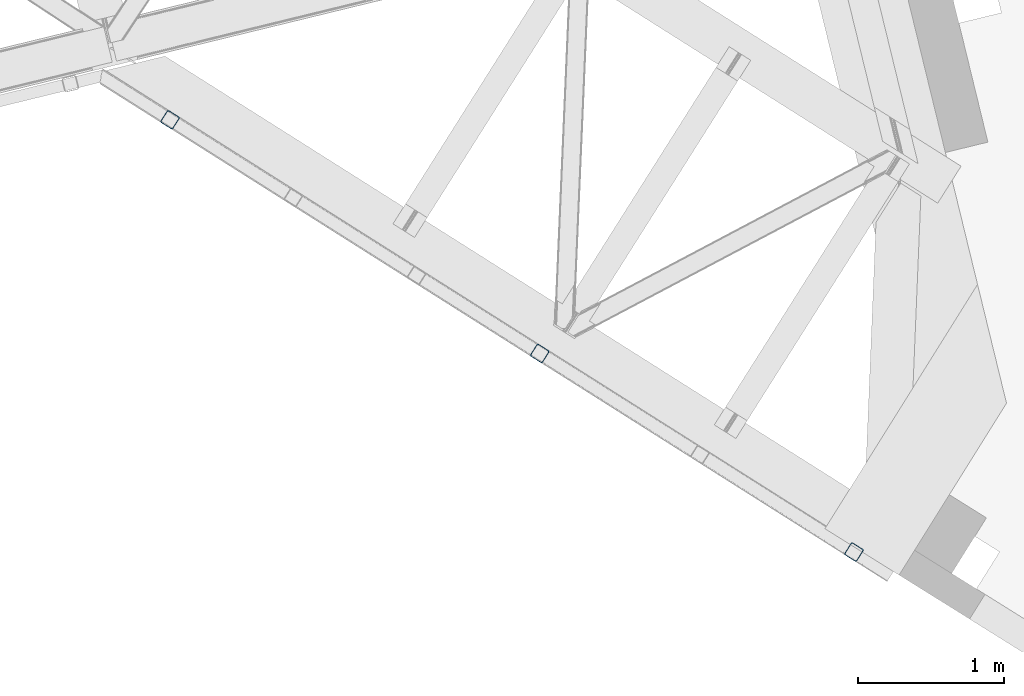
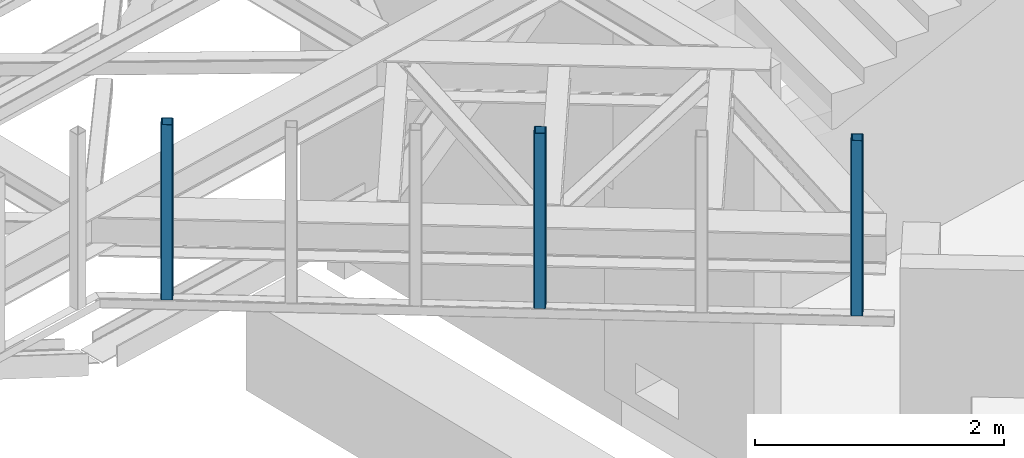
# One storey, part 9 of 67: 3 columns.
"""IFC4 building model written with IfcOpenShell, lengths in millimetres."""

from ifc_helpers import new_model, entity, si_unit, converted_unit, derived_unit, direction, frame, origin, place, context, subcontext, project, spatial, indexed_curve, outline, extrude, type_object, element, save


model = new_model("IFC4")

# Units and contexts
model_context = context("Model", 3, precision=0.01, world=origin(), true_north=direction((6.12303176911189e-17, 1.0)))
plan_context = context("Plan", 3, precision=0.01, world=origin(), true_north=direction((6.12303176911189e-17, 1.0)))
body_context = subcontext(model_context, "Body", "Model", "MODEL_VIEW")
ifc_project = project(units=[si_unit("LENGTHUNIT", "METRE", prefix="MILLI"), si_unit("AREAUNIT", "SQUARE_METRE"), si_unit("VOLUMEUNIT", "CUBIC_METRE"), converted_unit("PLANEANGLEUNIT", "DEGREE", entity("IfcRatioMeasure", 0.0174532925199433), si_unit("PLANEANGLEUNIT", "RADIAN"), dimensions=[0, 0, 0, 0, 0, 0, 0]), si_unit("MASSUNIT", "GRAM", prefix="KILO"), derived_unit("MASSDENSITYUNIT", [(si_unit("MASSUNIT", "GRAM", prefix="KILO"), 1), (si_unit("LENGTHUNIT", "METRE"), -3)]), derived_unit("MOMENTOFINERTIAUNIT", [(si_unit("LENGTHUNIT", "METRE"), 4)]), si_unit("TIMEUNIT", "SECOND"), si_unit("FREQUENCYUNIT", "HERTZ"), si_unit("THERMODYNAMICTEMPERATUREUNIT", "DEGREE_CELSIUS"), derived_unit("THERMALTRANSMITTANCEUNIT", [(si_unit("MASSUNIT", "GRAM", prefix="KILO"), 1), (si_unit("THERMODYNAMICTEMPERATUREUNIT", "KELVIN"), -1), (si_unit("TIMEUNIT", "SECOND"), -3)]), derived_unit("VOLUMETRICFLOWRATEUNIT", [(si_unit("LENGTHUNIT", "METRE"), 3), (si_unit("TIMEUNIT", "SECOND"), -1)]), derived_unit("MASSFLOWRATEUNIT", [(si_unit("MASSUNIT", "GRAM", prefix="KILO"), 1), (si_unit("TIMEUNIT", "SECOND"), -1)]), derived_unit("ROTATIONALFREQUENCYUNIT", [(si_unit("TIMEUNIT", "SECOND"), -1)]), si_unit("ELECTRICCURRENTUNIT", "AMPERE"), si_unit("ELECTRICVOLTAGEUNIT", "VOLT"), si_unit("POWERUNIT", "WATT"), si_unit("FORCEUNIT", "NEWTON", prefix="KILO"), si_unit("ILLUMINANCEUNIT", "LUX"), si_unit("LUMINOUSFLUXUNIT", "LUMEN"), si_unit("LUMINOUSINTENSITYUNIT", "CANDELA"), derived_unit("USERDEFINED", [(si_unit("MASSUNIT", "GRAM", prefix="KILO"), -1), (si_unit("LENGTHUNIT", "METRE"), -2), (si_unit("TIMEUNIT", "SECOND"), 3), (si_unit("LUMINOUSFLUXUNIT", "LUMEN"), 1)]), derived_unit("LINEARVELOCITYUNIT", [(si_unit("LENGTHUNIT", "METRE"), 1), (si_unit("TIMEUNIT", "SECOND"), -1)]), si_unit("PRESSUREUNIT", "PASCAL"), derived_unit("USERDEFINED", [(si_unit("LENGTHUNIT", "METRE"), -2), (si_unit("MASSUNIT", "GRAM", prefix="KILO"), 1), (si_unit("TIMEUNIT", "SECOND"), -2)]), derived_unit("LINEARFORCEUNIT", [(si_unit("MASSUNIT", "GRAM", prefix="KILO"), 1), (si_unit("LENGTHUNIT", "METRE"), 1), (si_unit("TIMEUNIT", "SECOND"), -2), (si_unit("LENGTHUNIT", "METRE"), -1)]), derived_unit("PLANARFORCEUNIT", [(si_unit("MASSUNIT", "GRAM", prefix="KILO"), 1), (si_unit("LENGTHUNIT", "METRE"), 1), (si_unit("TIMEUNIT", "SECOND"), -2), (si_unit("LENGTHUNIT", "METRE"), -2)])], contexts=[model_context, plan_context])

# Site, building, storey
site_placement = place(None, origin())
site = spatial("IfcSite", under=ifc_project, at=site_placement, CompositionType="ELEMENT")
building_placement = place(site_placement, origin())
building = spatial("IfcBuilding", under=site, at=building_placement, CompositionType="ELEMENT")
storey_placement = place(building_placement, frame((0.0, 0.0, 19800.0)))
storey = spatial("IfcBuildingStorey", under=building, at=storey_placement, CompositionType="ELEMENT", Elevation=19800.0)

# Columns
column_type_1 = type_object("IfcColumnType", PredefinedType="COLUMN")
column_1_placement = place(storey_placement, origin())
element("IfcColumn", 1, at=column_1_placement, inside=storey, type_object=column_type_1, ObjectType="Steel Column", PredefinedType="COLUMN", context=body_context, shape_type="SweptSolid", body=[
    extrude(outline(indexed_curve([(29.4768951149887, -56.8428769007626), (33.3787015553205, -56.8428769007626), (36.9835006653681, -55.3497202197607), (39.7424944582164, -52.5907264269385), (41.2356511392555, -48.9859273169046), (56.8428769010712, 29.4768951152554), (56.842876901092, 33.3787015555708), (55.3497202201102, 36.9835006656042), (52.5907264272972, 39.7424944584316), (48.9859273172661, 41.2356511394393), (-29.4768951149897, 56.8428769007575), (-33.3787015553141, 56.8428769007627), (-36.9835006653618, 55.3497202197608), (-39.7424944582241, 52.5907264269286), (-41.2356511392497, 48.9859273169045), (-56.8428769010719, -29.4768951152604), (-56.8428769011011, -33.3787015555789), (-55.3497202201039, -36.983500665604), (-52.5907264272974, -39.7424944584386), (-48.9859273172602, -41.2356511394394), (29.4768951149887, -56.8428769007626)], self_intersect=False), holes=[indexed_curve([(-43.1065493051361, -37.3071763475209), (-46.711348415166, -35.8140196665104), (-49.4703422079919, -33.0550258736856), (-50.9634988889722, -29.4502267636517), (-50.9634988889409, -25.5484203233276), (-37.307176347356, 43.1065493048057), (-35.8140196663157, 46.7113484148424), (-33.0550258734699, 49.4703422076636), (-29.4502267634194, 50.9634988886596), (-25.5484203231011, 50.9634988886614), (43.1065493051387, 37.3071763475173), (46.7113484151633, 35.8140196665024), (49.4703422079667, 33.0550258736713), (50.9634988889637, 29.4502267636392), (50.9634988889363, 25.5484203233305), (37.3071763473442, -43.1065493048172), (35.8140196663094, -46.7113484148471), (33.0550258734735, -49.4703422076669), (29.4502267634084, -50.9634988886731), (25.5484203230805, -50.963498888674), (-43.1065493051361, -37.3071763475209)], self_intersect=False)]), frame((-2465.33837501543, 14159.499292354, 3378.0106711256), z_axis=(0.0, 0.0, 1.0), x_axis=(-0.933262879926923, 0.359194093702145, 0.0)), (0.0, 0.0, 1.0), 1720.0000000002),
])
column_type_2 = type_object("IfcColumnType", PredefinedType="COLUMN")
column_2_placement = place(storey_placement, origin())
element("IfcColumn", 2, at=column_2_placement, inside=storey, type_object=column_type_2, ObjectType="Steel Column", PredefinedType="COLUMN", context=body_context, shape_type="SweptSolid", body=[
    extrude(outline(indexed_curve([(29.4768951150654, -56.8428769007209), (33.3787015553901, -56.8428769007209), (36.9835006654356, -55.3497202197144), (39.7424944582878, -52.5907264268834), (41.2356511393152, -48.9859273168526), (56.8428769010288, 29.4768951153275), (56.8428769010591, 33.3787015556532), (55.3497202200582, 36.9835006656744), (52.5907264272408, 39.7424944585002), (48.9859273172089, 41.2356511395014), (-29.4768951150681, 56.8428769007198), (-33.3787015553927, 56.8428769007198), (-36.9835006654375, 55.3497202197114), (-39.7424944582822, 52.5907264268856), (-41.2356511393169, 48.9859273168496), (-56.8428769010314, -29.4768951153285), (-56.8428769010475, -33.378701555644), (-55.3497202200599, -36.9835006656773), (-52.5907264272435, -39.7424944585012), (-48.9859273172105, -41.2356511395043), (29.4768951150654, -56.8428769007209)], self_intersect=False), holes=[indexed_curve([(-43.1065493050899, -37.307176347566), (-46.7113484151218, -35.8140196665695), (-49.4703422079311, -33.0550258737382), (-50.9634988889242, -29.4502267637071), (-50.9634988889087, -25.5484203233964), (-37.3071763473969, 43.1065493047724), (-35.8140196663806, 46.7113484147943), (-33.0550258735312, 49.4703422076219), (-29.4502267634749, 50.9634988886325), (-25.5484203231527, 50.9634988886292), (43.1065493050809, 37.3071763475603), (46.7113484151152, 35.8140196665623), (49.4703422079383, 33.0550258737433), (50.9634988889205, 29.4502267637149), (50.9634988889028, 25.5484203233918), (37.3071763474115, -43.1065493047505), (35.8140196663805, -46.7113484147943), (33.0550258735402, -49.4703422076207), (29.4502267634896, -50.9634988886338), (25.5484203231655, -50.9634988886336), (-43.1065493050899, -37.307176347566)], self_intersect=False)]), frame((-309.937604886291, 12796.8740613654, 3378.01067121164), z_axis=(0.0, 0.0, 1.0), x_axis=(-0.933262879926458, 0.359194093703355, 0.0)), (0.0, 0.0, 1.0), 1720.0000000002),
])
column_type_3 = type_object("IfcColumnType", PredefinedType="COLUMN")
column_3_placement = place(storey_placement, origin())
element("IfcColumn", 3, at=column_3_placement, inside=storey, type_object=column_type_3, ObjectType="Steel Column", PredefinedType="COLUMN", context=body_context, shape_type="SweptSolid", body=[
    extrude(outline(indexed_curve([(29.4768951149633, -56.8428769007716), (33.3787015552942, -56.8428769007716), (36.9835006653427, -55.3497202197717), (39.742494458185, -52.590726426956), (41.235651139218, -48.985927316926), (56.8428769010897, 29.4768951152342), (56.842876901112, 33.3787015555494), (55.3497202201253, 36.9835006655786), (52.590726427321, 39.7424944584125), (48.9859273172906, 41.2356511394221), (-29.4768951149575, 56.8428769007808), (-33.3787015552893, 56.8428769007828), (-36.983500665344, 55.3497202197781), (-39.7424944581937, 52.5907264269573), (-41.2356511392284, 48.9859273169289), (-56.8428769010847, -29.476895115223), (-56.8428769011151, -33.3787015555413), (-55.3497202201339, -36.9835006655773), (-52.590726427316, -39.7424944584013), (-48.9859273172857, -41.2356511394109), (29.4768951149633, -56.8428769007716)], self_intersect=False), holes=[indexed_curve([(-43.1065493051517, -37.3071763474948), (-46.7113484151879, -35.8140196664852), (-49.4703422080043, -33.0550258736559), (-50.9634988889827, -29.4502267636212), (-50.9634988889574, -25.5484203232956), (-37.3071763473315, 43.1065493048328), (-35.8140196662885, 46.7113484148667), (-33.05502587344, 49.4703422076847), (-29.4502267634012, 50.9634988886856), (-25.5484203230613, 50.9634988886774), (43.1065493051533, 37.3071763474815), (46.7113484151816, 35.8140196664804), (49.470342207997, 33.0550258736507), (50.9634988889759, 29.4502267636209), (50.9634988889449, 25.548420323307), (37.3071763473135, -43.1065493048281), (35.8140196662874, -46.7113484148579), (33.0550258734352, -49.4703422076842), (29.4502267633875, -50.9634988886862), (25.5484203230588, -50.963498888683), (-43.1065493051517, -37.3071763474948)], self_intersect=False)]), frame((-5001.10398692537, 15762.58779941, 3378.01067109185), z_axis=(0.0, 0.0, 1.0), x_axis=(-0.933262879927109, 0.359194093701662, 0.0)), (0.0, 0.0, 1.0), 1720.00000000022),
])

save(model, "model.ifc")
